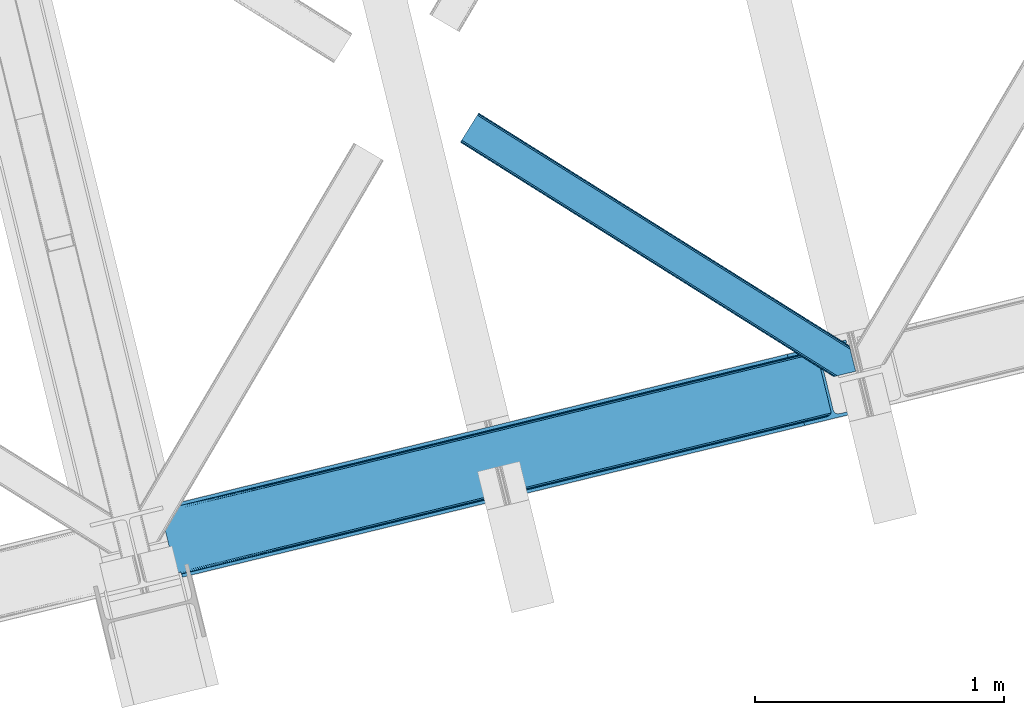
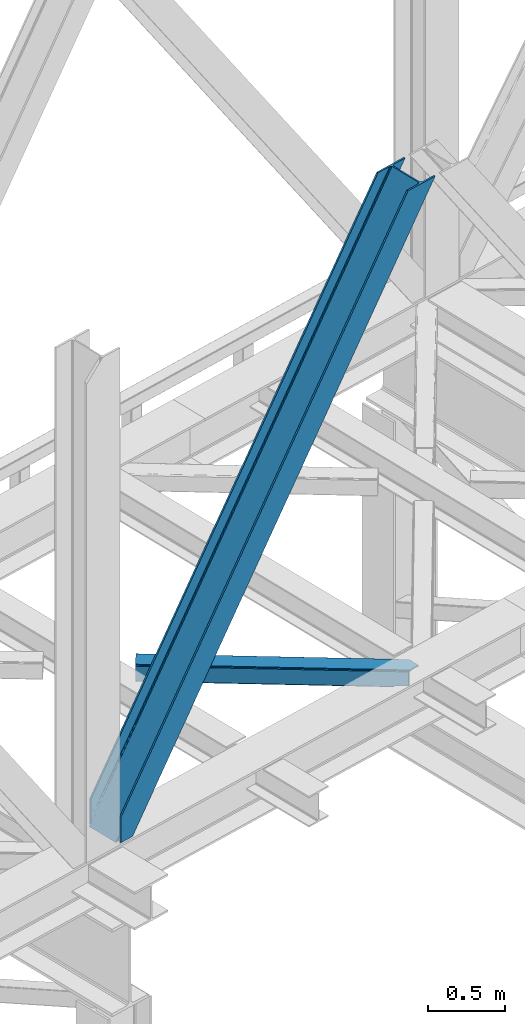
# One storey, part 34 of 92: 2 members.
"""IFC4 building model written with IfcOpenShell, lengths in millimetres."""

from ifc_helpers import new_model, entity, si_unit, converted_unit, derived_unit, direction, frame, origin, place, context, subcontext, project, spatial, triangles, type_object, element, save


model = new_model("IFC4")

# Units and contexts
model_context = context("Model", 3, precision=0.01, world=origin(), true_north=direction((6.12303176911189e-17, 1.0)))
plan_context = context("Plan", 3, precision=0.01, world=origin(), true_north=direction((6.12303176911189e-17, 1.0)))
body_context = subcontext(model_context, "Body", "Model", "MODEL_VIEW")
ifc_project = project(units=[si_unit("LENGTHUNIT", "METRE", prefix="MILLI"), si_unit("AREAUNIT", "SQUARE_METRE"), si_unit("VOLUMEUNIT", "CUBIC_METRE"), converted_unit("PLANEANGLEUNIT", "DEGREE", entity("IfcRatioMeasure", 0.0174532925199433), si_unit("PLANEANGLEUNIT", "RADIAN"), dimensions=[0, 0, 0, 0, 0, 0, 0]), si_unit("MASSUNIT", "GRAM", prefix="KILO"), derived_unit("MASSDENSITYUNIT", [(si_unit("MASSUNIT", "GRAM", prefix="KILO"), 1), (si_unit("LENGTHUNIT", "METRE"), -3)]), derived_unit("MOMENTOFINERTIAUNIT", [(si_unit("LENGTHUNIT", "METRE"), 4)]), si_unit("TIMEUNIT", "SECOND"), si_unit("FREQUENCYUNIT", "HERTZ"), si_unit("THERMODYNAMICTEMPERATUREUNIT", "DEGREE_CELSIUS"), derived_unit("THERMALTRANSMITTANCEUNIT", [(si_unit("MASSUNIT", "GRAM", prefix="KILO"), 1), (si_unit("THERMODYNAMICTEMPERATUREUNIT", "KELVIN"), -1), (si_unit("TIMEUNIT", "SECOND"), -3)]), derived_unit("VOLUMETRICFLOWRATEUNIT", [(si_unit("LENGTHUNIT", "METRE"), 3), (si_unit("TIMEUNIT", "SECOND"), -1)]), derived_unit("MASSFLOWRATEUNIT", [(si_unit("MASSUNIT", "GRAM", prefix="KILO"), 1), (si_unit("TIMEUNIT", "SECOND"), -1)]), derived_unit("ROTATIONALFREQUENCYUNIT", [(si_unit("TIMEUNIT", "SECOND"), -1)]), si_unit("ELECTRICCURRENTUNIT", "AMPERE"), si_unit("ELECTRICVOLTAGEUNIT", "VOLT"), si_unit("POWERUNIT", "WATT"), si_unit("FORCEUNIT", "NEWTON", prefix="KILO"), si_unit("ILLUMINANCEUNIT", "LUX"), si_unit("LUMINOUSFLUXUNIT", "LUMEN"), si_unit("LUMINOUSINTENSITYUNIT", "CANDELA"), derived_unit("USERDEFINED", [(si_unit("MASSUNIT", "GRAM", prefix="KILO"), -1), (si_unit("LENGTHUNIT", "METRE"), -2), (si_unit("TIMEUNIT", "SECOND"), 3), (si_unit("LUMINOUSFLUXUNIT", "LUMEN"), 1)]), derived_unit("LINEARVELOCITYUNIT", [(si_unit("LENGTHUNIT", "METRE"), 1), (si_unit("TIMEUNIT", "SECOND"), -1)]), si_unit("PRESSUREUNIT", "PASCAL"), derived_unit("USERDEFINED", [(si_unit("LENGTHUNIT", "METRE"), -2), (si_unit("MASSUNIT", "GRAM", prefix="KILO"), 1), (si_unit("TIMEUNIT", "SECOND"), -2)]), derived_unit("LINEARFORCEUNIT", [(si_unit("MASSUNIT", "GRAM", prefix="KILO"), 1), (si_unit("LENGTHUNIT", "METRE"), 1), (si_unit("TIMEUNIT", "SECOND"), -2), (si_unit("LENGTHUNIT", "METRE"), -1)]), derived_unit("PLANARFORCEUNIT", [(si_unit("MASSUNIT", "GRAM", prefix="KILO"), 1), (si_unit("LENGTHUNIT", "METRE"), 1), (si_unit("TIMEUNIT", "SECOND"), -2), (si_unit("LENGTHUNIT", "METRE"), -2)])], contexts=[model_context, plan_context])

# Site, building, storey
site_placement = place(None, origin())
site = spatial("IfcSite", under=ifc_project, at=site_placement, CompositionType="ELEMENT")
building_placement = place(site_placement, origin())
building = spatial("IfcBuilding", under=site, at=building_placement, CompositionType="ELEMENT")
storey_placement = place(building_placement, frame((0.0, 0.0, 15900.0)))
storey = spatial("IfcBuildingStorey", under=building, at=storey_placement, Name="05", CompositionType="ELEMENT", Elevation=15900.0)

# Members
member_type_1 = type_object("IfcMemberType", PredefinedType="BRACE")
member_1_placement = place(storey_placement, frame((-54343.52, 4224.3, 3695.0)))
element("IfcMember", 1, at=member_1_placement, inside=storey, type_object=member_type_1, ObjectType="Steel Vertical Brace", PredefinedType="BRACE", context=body_context, shape_type="Tessellation", body=[
    triangles([(58.5731689453169, 24.841216278076, 0.0), (60.4707275390683, 17.0687255859375, 0.0), (59.1126708984375, 17.8820480346685, 0.781347656247817), (58.97314453125, 16.7036315917967, 1.0697021484375), (71.428198242189, 19.7406555175785, 19.5569458007813), (71.428198242189, 19.7406555175785, 0.0), (499.290454101567, 119.170051574707, 658.75048828125), (75.71630859375, 19.9240745544439, 26.4030395507798), (79.7486206054746, 18.4526527404787, 34.3676696777329), (501.0252319336, 125.602798461914, 656.525042724606), (81.3299194335996, 17.2873168945316, 38.5441589355469), (2694.24484863281, 660.223363494873, 3911.00081176758), (2694.23089599609, 667.310721588135, 3911.00081176758), (2268.1359741211, 563.444677734376, 3278.7231262207), (2268.67082519532, 556.485800170899, 3279.50447387695), (2691.01248779297, 653.425522613526, 3911.00081176758), (2266.94069824219, 550.053053283692, 3281.72759399414), (2685.03145751954, 647.951147460938, 3911.00081176758), (2263.20139160156, 545.125737762452, 3285.05529785156), (2677.21333007813, 644.634780120849, 3911.00081176758), (2258.02961425782, 542.454098510742, 3288.98063964843), (490.379370117189, 111.571096801758, 666.003533935545), (495.555798339847, 114.242736053467, 662.07819213867), (84.4413574218779, 12.619287872315, 63.6403015136711), (83.9111572265683, 13.9000236511229, 51.2480346679658), (82.7484375000058, 15.4260932922361, 45.5251281738274), (500.485729980472, 132.561676025391, 655.74602050781), (942.937792968754, 233.323548889161, 1312.27106323242), (942.398291015626, 240.282426452637, 1311.48971557617), (1384.845703125, 341.044299316406, 1968.01475830078), (1384.31085205078, 348.003176879883, 1967.23341064453), (1826.75826416016, 448.765049743653, 2623.75845336914), (1826.22341308594, 455.723927307129, 2622.97710571289), (941.203015136722, 226.890802001953, 1314.49418334961), (1383.11557617188, 334.611552429199, 1970.23787841797), (1825.02813720703, 442.332302856445, 2625.98389892578), (937.468359375001, 221.963486480713, 1317.82188720703), (1379.37626953125, 329.68423690796, 1973.56790771484), (1821.28883056641, 437.404987335205, 2629.3116027832), (932.291931152344, 219.291847229004, 1321.74955444336), (1374.20449218751, 327.01259765625, 1977.49324951172), (1816.11705322266, 434.733348083496, 2633.23694458008), (84.4413574218779, 12.619287872315, 200.055230712889), (2585.27940673829, 622.225392150879, 3911.00081176758), (1329.12817382813, 574.374824523926, 1967.23341064453), (2639.05286865235, 893.682369232178, 3911.00081176758), (2212.95329589844, 789.816034698487, 3278.7231262207), (1771.04073486329, 682.095865631104, 2622.97710571289), (887.21561279297, 466.65407409668, 1311.48971557617), (445.307702636725, 358.933323669434, 655.74602050781), (3.3951416015625, 251.212863922119, 0.0), (2588.35828857422, 609.595058441162, 3911.00081176758), (84.7204101562529, 11.6585906982427, 200.120343017577), (87.5620971679746, 0.0, 200.120343017577), (87.5620971679746, 0.0, 0.0), (84.7204101562529, 11.6585906982427, 0.0), (72.8095092773438, 19.9851173400884, 0.0), (75.71630859375, 19.9240745544439, 3.35328369140552), (79.7486206054746, 18.4526527404787, 5.67639770507594), (77.6138671875015, 19.4549171447752, 4.89272460937354), (81.3299194335996, 17.2873168945316, 5.12991943359157), (82.9112182617246, 15.5499229431152, 2.42078247070094), (83.5158325195371, 14.6316650390627, 0.0), (189.179150390628, 24.769999694824, 0.0), (2824.83687744141, 667.239795684814, 3911.00081176758), (85.7296508789077, 14.7063697814947, 0.0), (94.1709960937515, 14.9909454345707, 0.0), (186.100268554692, 37.400333404541, 0.0), (2821.75799560547, 679.8698387146, 3911.00081176758), (1408.54193115234, 335.383016967774, 1950.37164916992), (2299.97124023438, 552.678183746338, 3273.1420715332), (1854.25891113281, 444.030745697021, 2611.75686035156), (2729.82872314454, 657.460741424561, 3911.00081176758), (962.829602050784, 226.735869598388, 1288.98643798828), (517.117272949225, 118.088140869141, 627.598901367186), (501.20661621094, 125.647853851318, 637.077392578125), (72.1583862304688, 21.124001312256, 0.0), (505.704016113283, 120.733618927002, 634.854272460936), (498.481201171875, 132.073624420166, 637.858740234373), (511.294372558594, 118.07912979126, 631.526568603513), (2721.35947265625, 656.806130218506, 3911.00081176758), (2294.14833984376, 552.668881988526, 3277.06973876953), (2713.53204345703, 658.914141082764, 3911.00081176758), (2288.56263427735, 555.323371124267, 3280.39744262695), (2707.53240966797, 663.46328201294, 3911.00081176758), (2284.065234375, 560.237606048584, 3282.62056274414), (2704.2814453125, 669.760572052002, 3911.00081176758), (2281.33981933594, 566.663376617432, 3283.40191040039), (68.6237182617188, 27.2910667419437, 0.0), (957.006701660161, 226.726567840577, 1292.91177978515), (1402.71903076172, 335.373715209961, 1954.2969909668), (1848.43135986329, 444.021443939209, 2615.68220214844), (951.420996093751, 229.381056976318, 1296.23948364258), (1397.13332519532, 338.028495025635, 1957.62469482422), (1842.84565429688, 446.675933074951, 2619.01223144531), (946.923596191409, 234.295291900635, 1298.46260375976), (1392.63592529297, 342.942729949951, 1959.85014038086), (1838.34825439454, 451.590167999268, 2621.2353515625), (944.198181152344, 240.721062469483, 1299.24395141601), (1389.91051025391, 349.368209838867, 1960.63148803711), (1835.62283935547, 458.015938568115, 2622.01669921875), (1780.44481201172, 684.387586212159, 2622.01669921875), (1334.72783203125, 575.73985748291, 1960.63148803711), (2649.10341796876, 896.132219696045, 3911.00081176758), (2226.15714111328, 793.035024261475, 3283.40191040039), (889.015502929688, 467.092710113526, 1299.24395141601), (443.303173828128, 358.445272064209, 637.858740234373), (13.4456909179717, 253.662714385987, 0.0), (1.49758300781832, 258.985063934327, 0.0), (12.4597045898481, 261.657284545899, 0.0), (13.7433471679688, 260.764025115967, 0.0), (13.7991577148496, 262.075282287597, 0.0), (0.0, 258.620260620118, 1.0697021484375), (12.4597045898481, 261.657284545899, 19.5569458007813), (0.669726562504366, 257.638343811035, 0.781347656247817), (438.084887695317, 370.273329162598, 658.75048828125), (432.499182128908, 372.928108978272, 662.07819213867), (20.8545410156294, 272.585105895996, 51.2480346679658), (20.7243164062529, 270.661095428467, 44.4996093749978), (442.582287597659, 365.359094238282, 656.525042724606), (16.3524902343779, 263.467348480225, 26.4030395507798), (19.8220458984433, 268.183339691162, 38.2720825195283), (19.254638671875, 266.629364776612, 34.3676696777329), (426.671630859375, 372.918807220459, 666.003533935545), (20.733618164064, 273.966707611085, 63.6403015136711), (2621.9748413086, 906.63622970581, 3911.00081176758), (2613.50559082031, 905.982199859619, 3911.00081176758), (2200.14477539063, 803.810529327393, 3285.05529785156), (2194.321875, 803.801808929444, 3288.98063964843), (2629.80227050782, 904.528800201416, 3911.00081176758), (2205.73048095703, 801.15604019165, 3281.72759399414), (2635.80190429688, 899.97965927124, 3911.00081176758), (2210.22788085938, 796.242386627197, 3279.50447387695), (874.407092285161, 480.648568725586, 1317.82188720703), (868.584191894537, 480.639266967773, 1321.74955444336), (1316.31965332032, 588.369319152832, 1973.56790771484), (1310.49675292969, 588.360308074952, 1977.49324951172), (1758.23221435547, 696.09036026001, 2629.3116027832), (1752.40931396485, 696.081058502197, 2633.23694458008), (879.992797851563, 477.994079589844, 1314.49418334961), (1321.90535888672, 585.71483001709, 1970.23787841797), (1763.81791992188, 693.435289764405, 2625.98389892578), (884.490197753912, 473.079844665527, 1312.27106323242), (1326.40275878907, 580.800595092774, 1968.01475830078), (1768.31531982422, 688.521054840088, 2623.75845336914), (2521.57631835938, 883.57310256958, 3911.00081176758), (20.733618164064, 273.966707611085, 200.055230712889), (16.3524902343779, 263.467348480225, 3.35328369140552), (19.254638671875, 266.629364776612, 5.67639770507594), (17.8221679687558, 264.760583496094, 4.89505004882813), (20.1197021484404, 268.390594482422, 5.12991943359157), (20.7243164062529, 270.661095428467, 2.42078247070094), (20.5429321289121, 274.94920578003, 0.0), (20.8405883789092, 271.754633331299, 0.0), (20.5429321289121, 274.94920578003, 200.120343017577), (22.8404663085967, 272.707191467285, 0.0), (448.233105468753, 376.764212036133, 631.526568603513), (444.498449707033, 371.836896514893, 634.854272460936), (30.4632568359375, 276.338655853272, 0.0), (442.763671875, 365.404149627686, 637.077392578125), (2649.08946533204, 903.219577789307, 3911.00081176758), (2225.62229003906, 799.993901824952, 3282.62056274414), (2652.32182617188, 910.017418670654, 3911.00081176758), (2227.35241699219, 806.426648712159, 3280.39744262695), (2658.30285644531, 915.491503143311, 3911.00081176758), (2231.09172363282, 811.353673553467, 3277.06973876953), (2666.12098388672, 918.808161163331, 3911.00081176758), (2236.26350097657, 814.025603485107, 3273.1420715332), (453.409533691411, 379.435851287842, 627.598901367186), (888.480651855469, 474.051587677002, 1298.46260375976), (1334.19298095704, 582.699025726319, 1959.85014038086), (1779.9053100586, 691.346463775635, 2621.2353515625), (890.2107788086, 480.484334564209, 1296.23948364258), (1335.92310791016, 589.131772613526, 1957.62469482422), (1781.64008789063, 697.779210662842, 2619.01223144531), (893.950085449222, 485.41165008545, 1292.91177978515), (1339.66241455078, 594.059088134766, 1954.2969909668), (1785.37474365235, 702.706235504151, 2615.68220214844), (899.12186279297, 488.083289337158, 1288.98643798828), (1344.83419189454, 596.730727386474, 1950.37164916992), (1790.55117187501, 705.378165435791, 2611.75686035156), (2518.49743652344, 896.203145599366, 3911.00081176758), (17.7012451171904, 286.607796478272, 200.120343017577), (17.7012451171904, 286.607796478272, 0.0), (2754.97602539063, 953.847301483154, 3911.00081176758), (2758.05490722656, 941.217258453369, 3911.00081176758), (119.318298339844, 311.378086853028, 0.0), (122.397180175787, 298.747753143311, 0.0)], [[1, 2, 3], [4, 3, 2], [5, 4, 6], [2, 6, 4], [7, 8, 9], [10, 3, 5], [5, 7, 10], [5, 8, 7], [3, 4, 5], [9, 11, 7], [12, 13, 14], [14, 15, 12], [16, 12, 15], [15, 17, 16], [18, 16, 17], [17, 19, 18], [20, 18, 19], [19, 21, 20], [22, 23, 24], [25, 24, 23], [25, 7, 26], [25, 23, 7], [11, 26, 7], [10, 27, 3], [1, 3, 27], [28, 29, 27], [27, 10, 28], [30, 31, 29], [29, 28, 30], [32, 33, 31], [31, 30, 32], [15, 14, 32], [33, 32, 14], [34, 28, 7], [10, 7, 28], [35, 30, 34], [28, 34, 30], [36, 32, 35], [30, 35, 32], [17, 15, 36], [32, 36, 15], [37, 34, 23], [7, 23, 34], [38, 35, 37], [34, 37, 35], [39, 36, 35], [35, 38, 39], [19, 17, 36], [36, 39, 19], [40, 37, 23], [23, 22, 40], [41, 38, 37], [37, 40, 41], [42, 39, 38], [38, 41, 42], [21, 19, 42], [39, 42, 19], [41, 43, 44], [44, 21, 42], [21, 44, 20], [42, 41, 44], [43, 41, 40], [40, 22, 43], [24, 43, 22], [33, 45, 31], [13, 46, 47], [48, 14, 47], [45, 33, 48], [47, 14, 13], [48, 33, 14], [31, 49, 29], [49, 50, 27], [49, 31, 45], [51, 1, 50], [49, 27, 29], [50, 1, 27], [52, 53, 54], [52, 44, 53], [43, 53, 44], [55, 54, 53], [53, 56, 55], [5, 6, 57], [58, 8, 5], [59, 9, 8], [8, 58, 60], [61, 26, 11], [61, 11, 9], [9, 59, 61], [56, 26, 62], [56, 25, 26], [56, 53, 24], [43, 24, 53], [24, 25, 56], [62, 63, 56], [61, 62, 26], [8, 60, 59], [57, 58, 5], [52, 64, 65], [64, 52, 54], [55, 64, 54], [66, 67, 56], [64, 67, 68], [67, 64, 55], [55, 56, 67], [56, 63, 66], [69, 65, 64], [64, 68, 69], [70, 69, 68], [71, 69, 72], [71, 73, 69], [70, 72, 69], [68, 74, 70], [75, 74, 68], [68, 67, 75], [76, 60, 58], [76, 59, 60], [58, 77, 76], [58, 57, 77], [76, 78, 61], [61, 59, 76], [79, 76, 77], [80, 75, 67], [80, 62, 61], [80, 66, 62], [66, 63, 62], [61, 78, 80], [67, 66, 80], [81, 73, 71], [71, 82, 81], [83, 81, 82], [82, 84, 83], [85, 83, 84], [84, 86, 85], [87, 85, 86], [86, 88, 87], [77, 89, 79], [90, 74, 75], [75, 80, 90], [91, 70, 90], [74, 90, 70], [92, 72, 91], [70, 91, 72], [82, 71, 92], [72, 92, 71], [93, 90, 78], [80, 78, 90], [94, 91, 93], [90, 93, 91], [95, 92, 94], [91, 94, 92], [84, 82, 95], [92, 95, 82], [96, 93, 78], [78, 76, 96], [97, 94, 93], [93, 96, 97], [98, 95, 94], [94, 97, 98], [86, 84, 95], [95, 98, 86], [99, 96, 79], [76, 79, 96], [100, 97, 96], [96, 99, 100], [101, 98, 100], [97, 100, 98], [88, 86, 101], [98, 101, 86], [102, 100, 103], [104, 87, 88], [101, 105, 88], [100, 102, 101], [88, 105, 104], [101, 102, 105], [103, 99, 106], [99, 79, 107], [99, 103, 100], [89, 108, 79], [99, 107, 106], [79, 108, 107], [108, 109, 110], [51, 108, 89], [108, 51, 109], [89, 1, 51], [2, 89, 6], [89, 2, 1], [77, 6, 89], [108, 110, 111], [112, 111, 110], [57, 6, 77], [113, 114, 110], [110, 109, 113], [109, 51, 115], [115, 113, 109], [116, 117, 118], [118, 119, 116], [120, 121, 114], [114, 115, 120], [114, 113, 115], [120, 116, 122], [122, 123, 120], [123, 121, 120], [119, 122, 116], [117, 124, 125], [125, 118, 117], [126, 127, 128], [129, 128, 127], [130, 126, 131], [128, 131, 126], [132, 130, 133], [131, 133, 130], [46, 132, 47], [133, 47, 132], [134, 135, 117], [124, 117, 135], [136, 137, 134], [135, 134, 137], [138, 139, 136], [137, 136, 139], [128, 129, 139], [139, 138, 128], [140, 134, 117], [117, 116, 140], [141, 136, 134], [134, 140, 141], [142, 138, 141], [136, 141, 138], [131, 128, 142], [138, 142, 128], [143, 140, 116], [116, 120, 143], [144, 141, 140], [140, 143, 144], [145, 142, 141], [141, 144, 145], [133, 131, 142], [142, 145, 133], [50, 120, 115], [115, 51, 50], [49, 143, 50], [120, 50, 143], [45, 144, 49], [143, 49, 144], [48, 145, 45], [144, 45, 145], [47, 133, 145], [145, 48, 47], [146, 147, 137], [137, 139, 146], [139, 129, 146], [127, 146, 129], [135, 137, 147], [147, 125, 124], [124, 135, 147], [114, 148, 112], [112, 110, 114], [149, 150, 121], [121, 123, 149], [151, 149, 123], [123, 122, 151], [119, 152, 151], [153, 118, 125], [153, 154, 152], [152, 119, 153], [119, 118, 153], [155, 153, 125], [125, 147, 155], [122, 119, 151], [150, 148, 121], [114, 121, 148], [156, 157, 152], [157, 158, 151], [151, 152, 157], [157, 156, 159], [107, 108, 111], [160, 149, 151], [160, 111, 148], [148, 150, 160], [150, 149, 160], [111, 112, 148], [151, 158, 160], [111, 160, 107], [161, 104, 162], [105, 162, 104], [163, 161, 164], [162, 164, 161], [165, 163, 166], [164, 166, 163], [167, 165, 168], [166, 168, 165], [159, 169, 157], [152, 154, 156], [170, 106, 107], [107, 160, 170], [171, 103, 170], [106, 170, 103], [172, 102, 103], [103, 171, 172], [162, 105, 102], [102, 172, 162], [173, 170, 160], [160, 158, 173], [174, 171, 173], [170, 173, 171], [175, 172, 174], [171, 174, 172], [164, 162, 172], [172, 175, 164], [176, 173, 157], [158, 157, 173], [177, 174, 173], [173, 176, 177], [178, 175, 174], [174, 177, 178], [166, 164, 178], [175, 178, 164], [179, 176, 169], [157, 169, 176], [180, 177, 176], [176, 179, 180], [181, 178, 177], [177, 180, 181], [168, 166, 178], [178, 181, 168], [182, 155, 146], [155, 182, 183], [155, 147, 146], [153, 155, 184], [183, 184, 155], [46, 13, 104], [16, 18, 81], [20, 52, 65], [44, 52, 20], [18, 20, 73], [13, 12, 85], [12, 16, 83], [130, 165, 126], [182, 127, 185], [127, 126, 167], [182, 146, 127], [130, 132, 163], [132, 46, 161], [104, 13, 87], [73, 81, 18], [85, 12, 83], [81, 83, 16], [85, 87, 13], [65, 73, 20], [65, 69, 73], [167, 126, 165], [163, 132, 161], [104, 161, 46], [163, 165, 130], [167, 185, 127], [185, 167, 186], [159, 156, 153], [187, 159, 184], [159, 187, 188], [154, 153, 156], [153, 184, 159], [182, 187, 183], [182, 185, 187], [187, 184, 183], [186, 180, 188], [181, 186, 168], [186, 181, 180], [186, 167, 168], [179, 188, 180], [159, 188, 169], [179, 169, 188], [185, 186, 188], [188, 187, 185]]),
])
member_type_2 = type_object("IfcMemberType", PredefinedType="BRACE")
member_2_placement = place(storey_placement, frame((-53139.2, 5030.3, 3511.0)))
element("IfcMember", 2, at=member_2_placement, inside=storey, type_object=member_type_2, ObjectType="Steel Horizontal Brace", PredefinedType="BRACE", context=body_context, shape_type="Tessellation", body=[
    triangles([(9.3017578125, 956.602656555176, 0.0), (65.1262573242202, 1045.53560028076, 0.0), (1381.50637207031, 219.293591308594, 0.0), (1417.18326416016, 72.9304321289064, 0.0), (1422.67595214844, 50.3934356689451, 10.8028289794929), (1423.12708740235, 48.5365722656252, 17.5000946044929), (0.0, 941.780305480957, 17.5000946044929), (0.706933593748545, 942.908724975586, 10.8028289794929), (1421.3876586914, 55.6814849853517, 5.12526855468968), (2.72541503906541, 946.121900939942, 5.12526855468968), (1419.45754394531, 63.5955368041996, 1.33247680664135), (5.74383544921875, 950.930328369141, 1.33247680664135), (68.6841796875015, 1051.2079284668, 1.33247680664135), (71.7026000976548, 1056.01693725586, 5.12526855468968), (1377.31127929688, 236.497773742676, 5.17061462402489), (73.7210815429717, 1059.22953186035, 10.8028289794929), (1382.10633544922, 238.005821228027, 10.8028289794929), (1383.91087646485, 238.445910644531, 17.5000946044929), (74.4280151367202, 1060.35795135498, 17.5000946044929), (1379.22744140625, 228.628486633301, 1.33247680664135), (1377.23221435547, 236.818684387207, 17.5198608398459), (1383.91087646485, 238.445910644531, 18.5197998046897), (1378.20424804687, 237.055297851563, 18.5197998046897), (1379.51114501953, 231.698648071289, 18.5197998046897), (1563.91384277344, 125.462690734864, 18.5197998046897), (1566.65321044922, 114.236631774903, 18.5197998046897), (1563.91384277344, 125.462690734864, 122.500662231447), (74.4280151367202, 1060.35795135498, 122.500662231447), (1564.36962890625, 123.605827331543, 129.197927856447), (73.7210815429717, 1059.22953186035, 129.197927856447), (1565.65792236328, 118.317778015137, 134.874325561526), (71.7026000976548, 1056.01693725586, 134.874325561526), (1567.58803710937, 110.403726196289, 138.667117309571), (68.6841796875015, 1051.2079284668, 138.667117309571), (1569.86231689453, 101.068830871583, 139.999594116212), (65.1262573242202, 1045.53560028076, 139.999594116212), (67.9818969726548, 1050.08764801025, 12.1260040283232), (1379.67857666016, 226.784994506836, 12.1260040283232), (1378.43214111328, 231.905612182617, 17.5198608398459), (70.0003784179717, 1053.30082397461, 17.8035644531265), (1566.29509277344, 115.705146789551, 24.4996673583992), (70.7073120117202, 1054.42924346924, 24.4996673583992), (1381.60869140625, 218.870942687989, 8.3320495605476), (64.9634765625015, 1045.27922058105, 8.3320495605476), (1383.88297119141, 209.536047363282, 6.99957275390625), (61.400903320311, 1039.60689239502, 6.99957275390625), (13.0271118164092, 962.531364440918, 6.99957275390625), (1414.80201416016, 82.6879760742186, 6.99957275390625), (1419.01105957032, 65.4390289306639, 12.1260040283232), (1420.25749511719, 60.3184112548834, 17.5198608398459), (1417.08094482422, 73.3530807495117, 8.3320495605476), (1566.29509277344, 115.705146789551, 115.501089477541), (70.7073120117202, 1054.42924346924, 115.501089477541), (1569.96463623047, 100.646182250976, 131.667544555665), (1572.23891601562, 91.3112869262695, 133.000021362306), (61.400903320311, 1039.60689239502, 133.000021362306), (64.9634765625015, 1045.27922058105, 131.667544555665), (1568.03452148438, 108.560234069824, 127.87475280762), (67.9818969726548, 1050.08764801025, 127.87475280762), (1566.74622802735, 113.848283386231, 122.196029663086), (70.0003784179717, 1053.30082397461, 122.196029663086), (1589.22392578125, 21.6376327514654, 133.000021362306), (1589.22392578125, 21.6376327514654, 139.999594116212), (9.3017578125, 956.602656555176, 139.999594116212), (1524.16743164063, 5.77987976074201, 139.999594116212), (1515.09356689453, 3.56780548095685, 138.667117309571), (5.74383544921875, 950.930328369141, 138.667117309571), (1507.4010131836, 1.69291992187482, 134.874325561526), (2.72541503906541, 946.121900939942, 134.874325561526), (1502.26179199219, 0.440089416503724, 129.197927856447), (0.706933593748545, 942.908724975586, 129.197927856447), (1500.45725097656, 0.0, 122.500662231447), (0.0, 941.780305480957, 122.500662231447), (1424.34561767578, 47.7738281250004, 18.5197998046897), (1500.45725097656, 0.0, 18.5197998046897), (1421.60625, 58.9998870849613, 18.5197998046897), (1511.36821289063, 2.65972137451172, 18.5197998046897), (3.720703125, 947.7090133667, 24.4996673583992), (1509.9403930664, 2.31206817626935, 24.4996673583992), (4.43228759765771, 948.837432861328, 17.8035644531265), (1420.9318725586, 59.6591491699219, 18.0198303222678), (6.44611816406541, 952.050608825683, 12.1260040283232), (9.46453857421875, 956.859036254883, 8.3320495605476), (6.44611816406541, 952.050608825683, 127.87475280762), (13.0271118164092, 962.531364440918, 133.000021362306), (9.46453857421875, 956.859036254883, 131.667544555665), (3.720703125, 947.7090133667, 115.501089477541), (4.43228759765771, 948.837432861328, 122.196029663086), (1524.57670898438, 5.87987365722711, 131.667544555665), (1516.88880615235, 4.00498809814508, 127.87475280762), (1511.74493408203, 2.75215759277398, 122.196029663086), (1533.65057373047, 8.09194793701226, 133.000021362306), (1509.9403930664, 2.31206817626935, 115.501089477541)], [[1, 2, 3], [3, 4, 1], [5, 6, 7], [7, 8, 5], [9, 5, 8], [8, 10, 9], [11, 9, 10], [10, 12, 11], [4, 11, 12], [12, 1, 4], [13, 14, 15], [16, 17, 15], [15, 14, 16], [18, 17, 19], [16, 19, 17], [20, 3, 2], [2, 13, 20], [15, 20, 13], [18, 21, 17], [18, 22, 23], [17, 21, 15], [21, 18, 23], [24, 22, 25], [22, 24, 23], [25, 26, 24], [25, 22, 27], [19, 22, 18], [22, 28, 27], [19, 28, 22], [29, 27, 30], [28, 30, 27], [31, 29, 32], [30, 32, 29], [33, 31, 34], [32, 34, 31], [35, 33, 36], [34, 36, 33], [37, 38, 39], [39, 40, 37], [24, 41, 42], [24, 26, 41], [42, 40, 39], [43, 38, 44], [37, 44, 38], [45, 43, 46], [44, 46, 43], [46, 47, 45], [48, 45, 47], [3, 48, 4], [43, 20, 38], [39, 15, 21], [15, 39, 38], [38, 20, 15], [43, 3, 20], [3, 45, 48], [43, 45, 3], [9, 49, 50], [50, 5, 9], [6, 5, 50], [49, 11, 51], [51, 4, 48], [4, 51, 11], [49, 9, 11], [41, 52, 53], [53, 42, 41], [54, 55, 56], [56, 57, 54], [58, 54, 57], [57, 59, 58], [60, 58, 59], [59, 61, 60], [52, 60, 61], [61, 53, 52], [58, 31, 33], [58, 33, 54], [55, 54, 35], [60, 31, 58], [62, 55, 63], [35, 63, 55], [54, 33, 35], [29, 31, 60], [25, 27, 52], [41, 25, 52], [25, 41, 26], [29, 60, 27], [60, 52, 27], [64, 35, 36], [35, 64, 65], [63, 35, 65], [66, 65, 64], [64, 67, 66], [68, 66, 67], [67, 69, 68], [70, 68, 69], [69, 71, 70], [72, 70, 71], [71, 73, 72], [74, 72, 6], [74, 75, 72], [73, 6, 72], [73, 7, 6], [74, 76, 77], [77, 75, 74], [78, 79, 76], [76, 80, 78], [76, 81, 80], [79, 77, 76], [50, 82, 80], [50, 49, 82], [51, 48, 83], [47, 83, 48], [49, 51, 82], [83, 82, 51], [16, 37, 40], [42, 28, 19], [16, 40, 19], [16, 14, 37], [40, 42, 19], [37, 14, 13], [46, 2, 1], [2, 44, 13], [44, 2, 46], [44, 37, 13], [30, 59, 32], [53, 28, 42], [28, 61, 30], [61, 28, 53], [30, 61, 59], [36, 56, 64], [34, 32, 59], [59, 57, 34], [57, 56, 36], [36, 34, 57], [82, 12, 10], [1, 47, 46], [1, 83, 47], [83, 1, 12], [82, 83, 12], [78, 7, 73], [8, 80, 82], [10, 8, 82], [80, 8, 7], [78, 80, 7], [67, 84, 69], [64, 56, 85], [85, 86, 64], [86, 84, 67], [67, 64, 86], [71, 69, 84], [73, 87, 78], [88, 73, 71], [73, 88, 87], [88, 71, 84], [89, 65, 66], [90, 66, 68], [91, 68, 70], [92, 63, 65], [89, 66, 90], [62, 63, 92], [89, 92, 65], [91, 90, 68], [72, 93, 91], [93, 72, 75], [79, 75, 77], [75, 79, 93], [72, 91, 70], [85, 55, 92], [85, 56, 55], [55, 62, 92], [91, 93, 88], [87, 88, 93], [90, 91, 84], [88, 84, 91], [89, 90, 86], [84, 86, 90], [92, 89, 85], [86, 85, 89], [93, 79, 78], [78, 87, 93]]),
])

save(model, "model.ifc")
